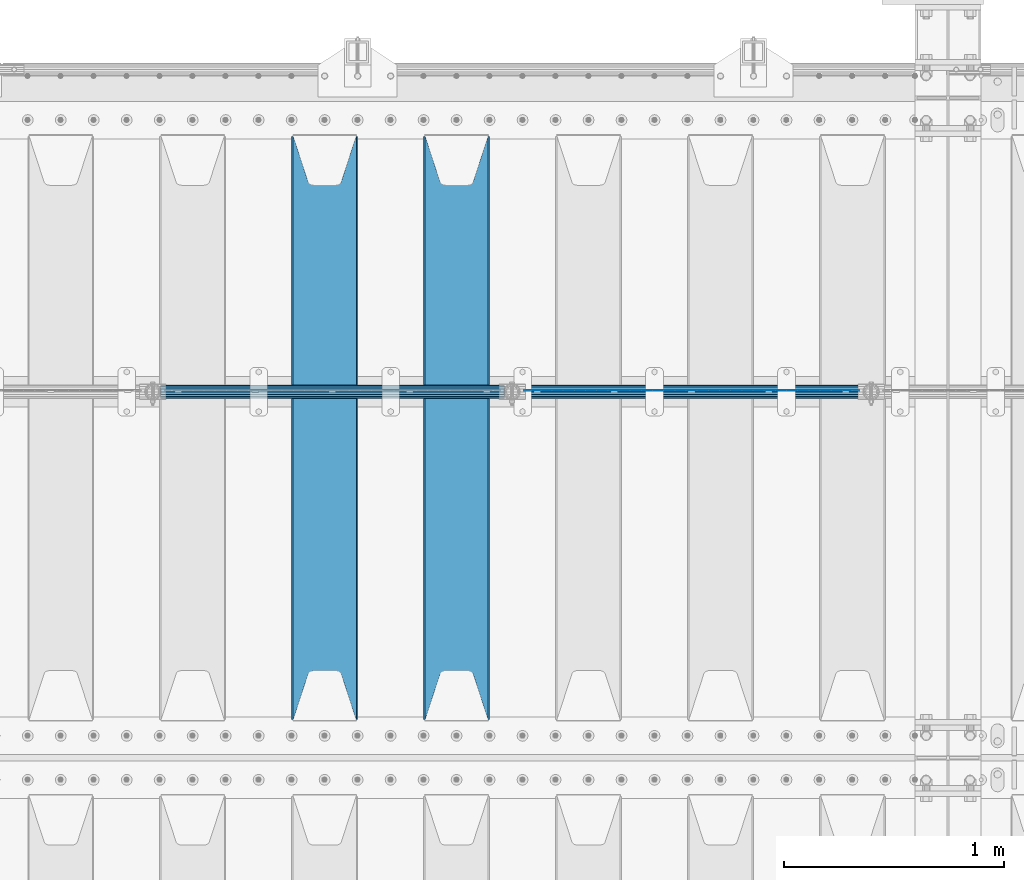
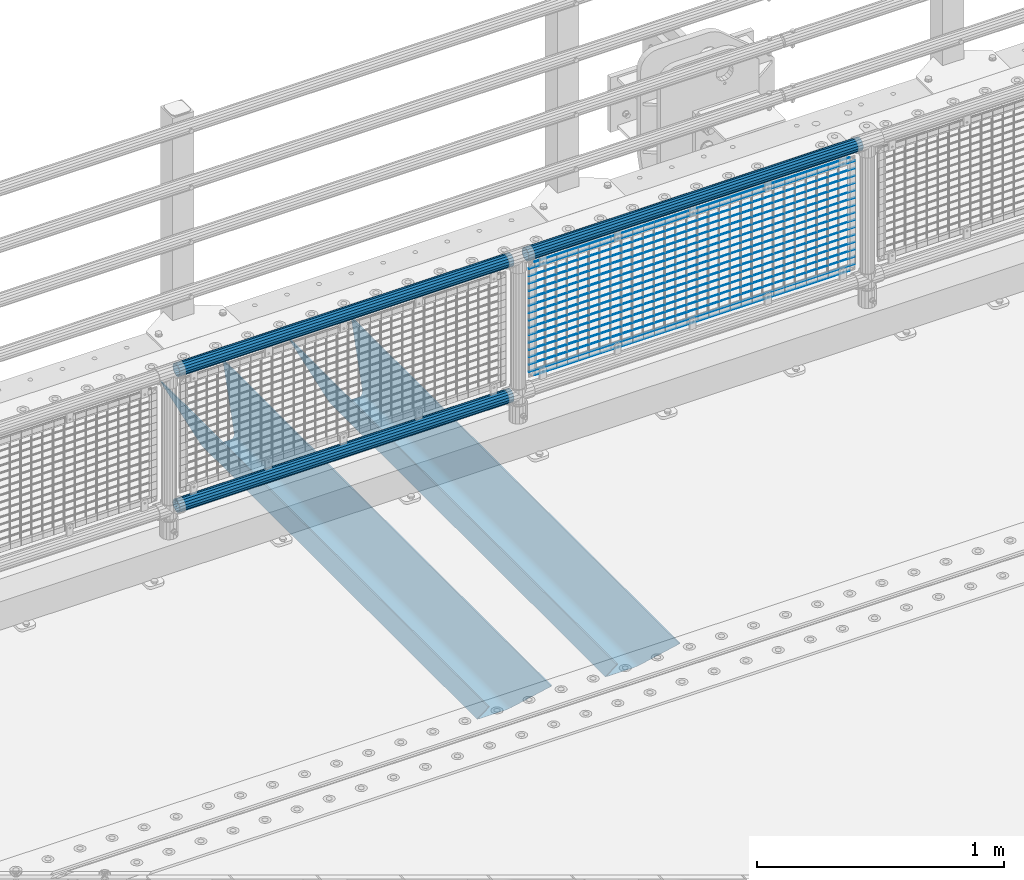
# One storey, part 125 of 242: 22 beams.
"""IFC2X3 building model written with IfcOpenShell, lengths in millimetres."""

from ifc_helpers import new_model, si_unit, frame, origin_with_axes, place, context, subcontext, project, spatial, faceted_brep, material, type_object, element, save


model = new_model("IFC2X3")

# Units and contexts
model_context = context("Model", 3, precision=1e-05, world=origin_with_axes())
body_context = subcontext(model_context, "Body", "Model", "MODEL_VIEW")
ifc_project = project(units=[si_unit("LENGTHUNIT", "METRE", prefix="MILLI"), si_unit("AREAUNIT", "SQUARE_METRE"), si_unit("VOLUMEUNIT", "CUBIC_METRE"), si_unit("MASSUNIT", "GRAM", prefix="KILO"), si_unit("TIMEUNIT", "SECOND"), si_unit("PLANEANGLEUNIT", "RADIAN"), si_unit("SOLIDANGLEUNIT", "STERADIAN"), si_unit("THERMODYNAMICTEMPERATUREUNIT", "DEGREE_CELSIUS"), si_unit("LUMINOUSINTENSITYUNIT", "LUMEN")], contexts=[model_context])

# Site, building, storey
site_placement = place(None, origin_with_axes())
site = spatial("IfcSite", under=ifc_project, at=site_placement, CompositionType="ELEMENT")
building_placement = place(site_placement, origin_with_axes())
building = spatial("IfcBuilding", under=site, at=building_placement, Name="Standard", CompositionType="ELEMENT")
storey_placement = place(building_placement, origin_with_axes())
storey = spatial("IfcBuildingStorey", under=building, at=storey_placement, Name="Undefined", CompositionType="ELEMENT", Elevation=0.0)

# Beams
ifc_material_1 = material(Name="Misc_Undefined")
beam_type_1 = type_object("IfcBeamType", Name="D3", PredefinedType="NOTDEFINED")
for number, where, z_axis, x_axis in (
    (1, (-30343.0, -19329.5, 851.596999999999), (0.0, 0.0, 1.0), (1.0, 0.0, 0.0)),
    (2, (-30343.0, -19329.5, 669.452), (0.0, 0.0, 1.0), (1.0, 0.0, 0.0)),
    (3, (-30343.0, -19329.5, 523.736), (0.0, 0.0, 1.0), (1.0, 0.0, 0.0)),
    (4, (-30343.0, -19329.5, 487.307), (0.0, 0.0, 1.0), (1.0, 0.0, 0.0)),
    (5, (-30343.0, -19329.5, 705.881), (0.0, 0.0, 1.0), (1.0, 0.0, 0.0)),
    (6, (-30343.0, -19329.5, 596.594), (0.0, 0.0, 1.0), (1.0, 0.0, 0.0)),
    (7, (-30343.0, -19329.5, 450.878), (0.0, 0.0, 1.0), (1.0, 0.0, 0.0)),
    (8, (-30343.0, -19329.5, 815.167999999999), (0.0, 0.0, 1.0), (1.0, 0.0, 0.0)),
    (9, (-30343.0, -19329.5, 888.025999999999), (0.0, 0.0, 1.0), (1.0, 0.0, 0.0)),
    (10, (-30343.0, -19329.5, 778.738999999999), (0.0, 0.0, 1.0), (1.0, 0.0, 0.0)),
    (11, (-30343.0, -19329.5, 742.309999999999), (0.0, 0.0, 1.0), (1.0, 0.0, 0.0)),
    (12, (-30343.0, -19329.5, 633.023), (0.0, 0.0, 1.0), (1.0, 0.0, 0.0)),
    (13, (-30343.0, -19329.5, 560.165), (0.0, 0.0, 1.0), (1.0, 0.0, 0.0)),
    (14, (-30343.0, -19329.5, 414.449), (0.0, 0.0, 1.0), (1.0, 0.0, 0.0)),
):
    element("IfcBeam", number, at=place(storey_placement, frame(where, z_axis=z_axis, x_axis=x_axis)), inside=storey, type_object=beam_type_1, material=ifc_material_1, ObjectType="D3", context=body_context, shape_type="Brep", body=[
        faceted_brep([(0.0, -1.50000000000364, 0.0), (-3.63797880709171e-12, -0.750000000003638, -1.29903810567669), (1523.0, -0.75, -1.29903810567669), (1523.0, -1.5, 0.0), (0.0, 0.749999999996362, -1.29903810567669), (1523.0, 0.75, -1.29903810567669), (-3.63797880709171e-12, 1.49999999999636, 0.0), (1523.0, 1.5, 0.0), (0.0, 0.749999999996362, 1.29903810567669), (1523.0, 0.75, 1.29903810567669), (-3.63797880709171e-12, -0.750000000003638, 1.29903810567669), (1523.0, -0.75, 1.29903810567669)], [[[0, 1, 2, 3]], [[1, 4, 5, 2]], [[4, 6, 7, 5]], [[6, 8, 9, 7]], [[8, 10, 11, 9]], [[10, 0, 3, 11]], [[5, 7, 9, 11, 3, 2]], [[10, 8, 6, 4, 1, 0]]]),
    ])
beam_1_placement = place(storey_placement, frame((-30318.0, -19329.5, 353.02), z_axis=(0.0, 0.0, 1.0), x_axis=(1.0, 0.0, 0.0)))
element("IfcBeam", 15, at=beam_1_placement, inside=storey, type_object=beam_type_1, material=ifc_material_1, ObjectType="D3", context=body_context, shape_type="Brep", body=[
    faceted_brep([(0.0, -1.50000000000364, 0.0), (-3.63797880709171e-12, -0.750000000003638, -1.29903810567669), (1473.0, -0.75, -1.29903810567669), (1473.0, -1.5, 0.0), (0.0, 0.749999999996362, -1.29903810567669), (1473.0, 0.75, -1.29903810567663), (-3.63797880709171e-12, 1.49999999999636, 0.0), (1473.0, 1.5, 0.0), (0.0, 0.749999999996362, 1.29903810567669), (1473.0, 0.75, 1.29903810567669), (-3.63797880709171e-12, -0.750000000003638, 1.29903810567669), (1473.0, -0.75, 1.29903810567669)], [[[0, 1, 2, 3]], [[1, 4, 5, 2]], [[4, 6, 7, 5]], [[6, 8, 9, 7]], [[8, 10, 11, 9]], [[10, 0, 3, 11]], [[5, 7, 9, 11, 3, 2]], [[10, 8, 6, 4, 1, 0]]]),
])
beam_2_placement = place(storey_placement, frame((-30343.0, -19329.5, 378.02), z_axis=(0.0, 0.0, 1.0), x_axis=(1.0, 0.0, 0.0)))
element("IfcBeam", 16, at=beam_2_placement, inside=storey, type_object=beam_type_1, material=ifc_material_1, ObjectType="D3", context=body_context, shape_type="Brep", body=[
    faceted_brep([(0.0, -1.50000000000364, 0.0), (-3.63797880709171e-12, -0.750000000003638, -1.29903810567669), (1523.0, -0.75, -1.29903810567669), (1523.0, -1.5, 0.0), (0.0, 0.749999999996362, -1.29903810567669), (1523.0, 0.75, -1.29903810567669), (-3.63797880709171e-12, 1.49999999999636, 0.0), (1523.0, 1.5, 0.0), (0.0, 0.749999999996362, 1.29903810567669), (1523.0, 0.75, 1.29903810567669), (-3.63797880709171e-12, -0.750000000003638, 1.29903810567669), (1523.0, -0.75, 1.29903810567669)], [[[0, 1, 2, 3]], [[1, 4, 5, 2]], [[4, 6, 7, 5]], [[6, 8, 9, 7]], [[8, 10, 11, 9]], [[10, 0, 3, 11]], [[5, 7, 9, 11, 3, 2]], [[10, 8, 6, 4, 1, 0]]]),
])
beam_3_placement = place(storey_placement, frame((-30318.0, -19329.5, 913.02), z_axis=(0.0, 0.0, 1.0), x_axis=(1.0, 0.0, 0.0)))
element("IfcBeam", 17, at=beam_3_placement, inside=storey, type_object=beam_type_1, material=ifc_material_1, ObjectType="D3", context=body_context, shape_type="Brep", body=[
    faceted_brep([(0.0, -1.50000000000364, 0.0), (-3.63797880709171e-12, -0.750000000003638, -1.29903810567669), (1473.0, -0.75, -1.29903810567669), (1473.0, -1.5, 0.0), (0.0, 0.749999999996362, -1.29903810567669), (1473.0, 0.75, -1.29903810567663), (-3.63797880709171e-12, 1.49999999999636, 0.0), (1473.0, 1.5, 0.0), (0.0, 0.749999999996362, 1.29903810567669), (1473.0, 0.75, 1.29903810567669), (-3.63797880709171e-12, -0.750000000003638, 1.29903810567669), (1473.0, -0.75, 1.29903810567669)], [[[0, 1, 2, 3]], [[1, 4, 5, 2]], [[4, 6, 7, 5]], [[6, 8, 9, 7]], [[8, 10, 11, 9]], [[10, 0, 3, 11]], [[5, 7, 9, 11, 3, 2]], [[10, 8, 6, 4, 1, 0]]]),
])
ifc_material_2 = material()
beam_type_2 = type_object("IfcBeamType", PredefinedType="NOTDEFINED")
beam_4_placement = place(storey_placement, frame((-30363.15, -19335.5, 969.849999999999), z_axis=(0.0, 0.0, 1.0), x_axis=(1.0, 0.0, 0.0)))
element("IfcBeam", 18, at=beam_4_placement, inside=storey, type_object=beam_type_2, material=ifc_material_2, context=body_context, shape_type="Brep", body=[
    faceted_brep([(0.0, -25.3499999999985, 0.0), (0.0, -23.4203461491597, 9.70102501045403), (1563.0, -23.4203461491597, 9.70102501045506), (1563.0, -25.3499999999985, 0.0), (0.0, -17.9251569030785, 17.9251569030785), (1563.0, -17.9251569030785, 17.925156903079), (0.0, -9.70102501045403, 23.4203461491597), (1563.0, -9.70102501045403, 23.4203461491611), (0.0, 0.0, 25.3499999999985), (1563.0, 0.0, 25.35), (0.0, 9.70102501045403, 23.4203461491597), (1563.0, 9.70102501045403, 23.4203461491611), (0.0, 17.9251569030785, 17.9251569030785), (1563.0, 17.9251569030785, 17.925156903079), (0.0, 23.4203461491597, 9.70102501045403), (1563.0, 23.4203461491597, 9.70102501045506), (0.0, 25.3499999999985, 0.0), (1563.0, 25.3499999999985, 0.0), (0.0, 23.4203461491597, -9.70102501045403), (1563.0, 23.4203461491597, -9.70102501045506), (0.0, 17.9251569030785, -17.9251569030785), (1563.0, 17.9251569030785, -17.925156903079), (0.0, 9.70102501045403, -23.4203461491597), (1563.0, 9.70102501045403, -23.4203461491611), (0.0, 0.0, -25.3499999999985), (1563.0, 0.0, -25.35), (0.0, -9.70102501045403, -23.4203461491597), (1563.0, -9.70102501045403, -23.4203461491611), (0.0, -17.9251569030785, -17.9251569030785), (1563.0, -17.9251569030785, -17.925156903079), (0.0, -23.4203461491597, -9.70102501045403), (1563.0, -23.4203461491597, -9.70102501045506), (0.0, -30.1500000000015, 0.0), (0.0, -27.8549679052157, -11.5379054858058), (1563.0, -27.8549679052157, -11.5379054858075), (1563.0, -30.1500000000015, 0.0), (0.0, -21.3192694527752, -21.3192694527752), (1563.0, -21.3192694527752, -21.3192694527744), (0.0, -11.5379054858058, -27.8549679052157), (1563.0, -11.5379054858058, -27.8549679052153), (0.0, 0.0, -30.1500000000015), (1563.0, 0.0, -30.15), (0.0, 11.5379054858058, -27.8549679052157), (1563.0, 11.5379054858058, -27.8549679052153), (0.0, 21.3192694527752, -21.3192694527752), (1563.0, 21.3192694527752, -21.3192694527744), (0.0, 27.8549679052157, -11.5379054858058), (1563.0, 27.8549679052157, -11.5379054858074), (0.0, 30.1500000000015, 0.0), (1563.0, 30.1500000000015, 0.0), (0.0, 27.8549679052157, 11.5379054858058), (1563.0, 27.8549679052157, 11.5379054858074), (0.0, 21.3192694527752, 21.3192694527752), (1563.0, 21.3192694527752, 21.3192694527744), (0.0, 11.5379054858058, 27.8549679052157), (1563.0, 11.5379054858058, 27.8549679052153), (0.0, 0.0, 30.1500000000015), (1563.0, 0.0, 30.15), (0.0, -11.5379054858058, 27.8549679052157), (1563.0, -11.5379054858058, 27.8549679052153), (0.0, -21.3192694527752, 21.3192694527752), (1563.0, -21.3192694527752, 21.3192694527744), (0.0, -27.8549679052157, 11.5379054858058), (1563.0, -27.8549679052157, 11.5379054858074)], [[[0, 1, 2, 3]], [[1, 4, 5, 2]], [[4, 6, 7, 5]], [[6, 8, 9, 7]], [[8, 10, 11, 9]], [[10, 12, 13, 11]], [[12, 14, 15, 13]], [[14, 16, 17, 15]], [[16, 18, 19, 17]], [[18, 20, 21, 19]], [[20, 22, 23, 21]], [[22, 24, 25, 23]], [[24, 26, 27, 25]], [[26, 28, 29, 27]], [[28, 30, 31, 29]], [[30, 0, 3, 31]], [[32, 33, 34, 35]], [[33, 36, 37, 34]], [[36, 38, 39, 37]], [[38, 40, 41, 39]], [[40, 42, 43, 41]], [[42, 44, 45, 43]], [[44, 46, 47, 45]], [[46, 48, 49, 47]], [[48, 50, 51, 49]], [[50, 52, 53, 51]], [[52, 54, 55, 53]], [[54, 56, 57, 55]], [[56, 58, 59, 57]], [[58, 60, 61, 59]], [[60, 62, 63, 61]], [[62, 32, 35, 63]], [[37, 39, 41, 43, 45, 47, 49, 51, 53, 55, 57, 59, 61, 63, 35, 34], [5, 7, 9, 11, 13, 15, 17, 19, 21, 23, 25, 27, 29, 31, 3, 2]], [[62, 60, 58, 56, 54, 52, 50, 48, 46, 44, 42, 40, 38, 36, 33, 32], [30, 28, 26, 24, 22, 20, 18, 16, 14, 12, 10, 8, 6, 4, 1, 0]]]),
])
beam_5_placement = place(storey_placement, frame((-31996.15, -19335.5, 969.849999999999), z_axis=(0.0, 0.0, 1.0), x_axis=(1.0, 0.0, 0.0)))
element("IfcBeam", 19, at=beam_5_placement, inside=storey, type_object=beam_type_2, material=ifc_material_2, context=body_context, shape_type="Brep", body=[
    faceted_brep([(0.0, -25.3499999999985, 0.0), (0.0, -23.4203461491597, 9.70102501045403), (1563.0, -23.4203461491597, 9.70102501045506), (1563.0, -25.3499999999985, 0.0), (0.0, -17.9251569030785, 17.9251569030785), (1563.0, -17.9251569030785, 17.925156903079), (0.0, -9.70102501045403, 23.4203461491597), (1563.0, -9.70102501045403, 23.4203461491611), (0.0, 0.0, 25.3499999999985), (1563.0, 0.0, 25.35), (0.0, 9.70102501045403, 23.4203461491597), (1563.0, 9.70102501045403, 23.4203461491611), (0.0, 17.9251569030785, 17.9251569030785), (1563.0, 17.9251569030785, 17.925156903079), (0.0, 23.4203461491597, 9.70102501045403), (1563.0, 23.4203461491597, 9.70102501045506), (0.0, 25.3499999999985, 0.0), (1563.0, 25.3499999999985, 0.0), (0.0, 23.4203461491597, -9.70102501045403), (1563.0, 23.4203461491597, -9.70102501045506), (0.0, 17.9251569030785, -17.9251569030785), (1563.0, 17.9251569030785, -17.925156903079), (0.0, 9.70102501045403, -23.4203461491597), (1563.0, 9.70102501045403, -23.4203461491611), (0.0, 0.0, -25.3499999999985), (1563.0, 0.0, -25.35), (0.0, -9.70102501045403, -23.4203461491597), (1563.0, -9.70102501045403, -23.4203461491611), (0.0, -17.9251569030785, -17.9251569030785), (1563.0, -17.9251569030785, -17.925156903079), (0.0, -23.4203461491597, -9.70102501045403), (1563.0, -23.4203461491597, -9.70102501045506), (0.0, -30.1500000000015, 0.0), (0.0, -27.8549679052157, -11.5379054858058), (1563.0, -27.8549679052157, -11.5379054858075), (1563.0, -30.1500000000015, 0.0), (0.0, -21.3192694527752, -21.3192694527752), (1563.0, -21.3192694527752, -21.3192694527744), (0.0, -11.5379054858058, -27.8549679052157), (1563.0, -11.5379054858058, -27.8549679052153), (0.0, 0.0, -30.1500000000015), (1563.0, 0.0, -30.15), (0.0, 11.5379054858058, -27.8549679052157), (1563.0, 11.5379054858058, -27.8549679052153), (0.0, 21.3192694527752, -21.3192694527752), (1563.0, 21.3192694527752, -21.3192694527744), (0.0, 27.8549679052157, -11.5379054858058), (1563.0, 27.8549679052157, -11.5379054858074), (0.0, 30.1500000000015, 0.0), (1563.0, 30.1500000000015, 0.0), (0.0, 27.8549679052157, 11.5379054858058), (1563.0, 27.8549679052157, 11.5379054858074), (0.0, 21.3192694527752, 21.3192694527752), (1563.0, 21.3192694527752, 21.3192694527744), (0.0, 11.5379054858058, 27.8549679052157), (1563.0, 11.5379054858058, 27.8549679052153), (0.0, 0.0, 30.1500000000015), (1563.0, 0.0, 30.15), (0.0, -11.5379054858058, 27.8549679052157), (1563.0, -11.5379054858058, 27.8549679052153), (0.0, -21.3192694527752, 21.3192694527752), (1563.0, -21.3192694527752, 21.3192694527744), (0.0, -27.8549679052157, 11.5379054858058), (1563.0, -27.8549679052157, 11.5379054858074)], [[[0, 1, 2, 3]], [[1, 4, 5, 2]], [[4, 6, 7, 5]], [[6, 8, 9, 7]], [[8, 10, 11, 9]], [[10, 12, 13, 11]], [[12, 14, 15, 13]], [[14, 16, 17, 15]], [[16, 18, 19, 17]], [[18, 20, 21, 19]], [[20, 22, 23, 21]], [[22, 24, 25, 23]], [[24, 26, 27, 25]], [[26, 28, 29, 27]], [[28, 30, 31, 29]], [[30, 0, 3, 31]], [[32, 33, 34, 35]], [[33, 36, 37, 34]], [[36, 38, 39, 37]], [[38, 40, 41, 39]], [[40, 42, 43, 41]], [[42, 44, 45, 43]], [[44, 46, 47, 45]], [[46, 48, 49, 47]], [[48, 50, 51, 49]], [[50, 52, 53, 51]], [[52, 54, 55, 53]], [[54, 56, 57, 55]], [[56, 58, 59, 57]], [[58, 60, 61, 59]], [[60, 62, 63, 61]], [[62, 32, 35, 63]], [[37, 39, 41, 43, 45, 47, 49, 51, 53, 55, 57, 59, 61, 63, 35, 34], [5, 7, 9, 11, 13, 15, 17, 19, 21, 23, 25, 27, 29, 31, 3, 2]], [[62, 60, 58, 56, 54, 52, 50, 48, 46, 44, 42, 40, 38, 36, 33, 32], [30, 28, 26, 24, 22, 20, 18, 16, 14, 12, 10, 8, 6, 4, 1, 0]]]),
])
beam_6_placement = place(storey_placement, frame((-31996.15, -19335.5, 298.170000000001), z_axis=(0.0, 0.0, 1.0), x_axis=(1.0, 0.0, 0.0)))
element("IfcBeam", 20, at=beam_6_placement, inside=storey, type_object=beam_type_2, material=ifc_material_2, context=body_context, shape_type="Brep", body=[
    faceted_brep([(0.0, -25.3499999999985, 0.0), (0.0, -23.4203461491597, 9.70102501045403), (1563.0, -23.4203461491597, 9.70102501045506), (1563.0, -25.3499999999985, 0.0), (0.0, -17.9251569030785, 17.9251569030785), (1563.0, -17.9251569030785, 17.925156903079), (0.0, -9.70102501045403, 23.4203461491597), (1563.0, -9.70102501045403, 23.4203461491611), (0.0, 0.0, 25.3499999999985), (1563.0, 0.0, 25.35), (0.0, 9.70102501045403, 23.4203461491597), (1563.0, 9.70102501045403, 23.4203461491611), (0.0, 17.9251569030785, 17.9251569030785), (1563.0, 17.9251569030785, 17.925156903079), (0.0, 23.4203461491597, 9.70102501045403), (1563.0, 23.4203461491597, 9.70102501045506), (0.0, 25.3499999999985, 0.0), (1563.0, 25.3499999999985, 0.0), (0.0, 23.4203461491597, -9.70102501045403), (1563.0, 23.4203461491597, -9.70102501045506), (0.0, 17.9251569030785, -17.9251569030785), (1563.0, 17.9251569030785, -17.925156903079), (0.0, 9.70102501045403, -23.4203461491597), (1563.0, 9.70102501045403, -23.4203461491611), (0.0, 0.0, -25.3499999999985), (1563.0, 0.0, -25.35), (0.0, -9.70102501045403, -23.4203461491597), (1563.0, -9.70102501045403, -23.4203461491611), (0.0, -17.9251569030785, -17.9251569030785), (1563.0, -17.9251569030785, -17.925156903079), (0.0, -23.4203461491597, -9.70102501045403), (1563.0, -23.4203461491597, -9.70102501045506), (0.0, -30.1500000000015, 0.0), (0.0, -27.8549679052157, -11.5379054858058), (1563.0, -27.8549679052157, -11.5379054858075), (1563.0, -30.1500000000015, 0.0), (0.0, -21.3192694527752, -21.3192694527752), (1563.0, -21.3192694527752, -21.3192694527744), (0.0, -11.5379054858058, -27.8549679052157), (1563.0, -11.5379054858058, -27.8549679052153), (0.0, 0.0, -30.1500000000015), (1563.0, 0.0, -30.15), (0.0, 11.5379054858058, -27.8549679052157), (1563.0, 11.5379054858058, -27.8549679052153), (0.0, 21.3192694527752, -21.3192694527752), (1563.0, 21.3192694527752, -21.3192694527744), (0.0, 27.8549679052157, -11.5379054858058), (1563.0, 27.8549679052157, -11.5379054858074), (0.0, 30.1500000000015, 0.0), (1563.0, 30.1500000000015, 0.0), (0.0, 27.8549679052157, 11.5379054858058), (1563.0, 27.8549679052157, 11.5379054858074), (0.0, 21.3192694527752, 21.3192694527752), (1563.0, 21.3192694527752, 21.3192694527744), (0.0, 11.5379054858058, 27.8549679052157), (1563.0, 11.5379054858058, 27.8549679052153), (0.0, 0.0, 30.1500000000015), (1563.0, 0.0, 30.15), (0.0, -11.5379054858058, 27.8549679052157), (1563.0, -11.5379054858058, 27.8549679052153), (0.0, -21.3192694527752, 21.3192694527752), (1563.0, -21.3192694527752, 21.3192694527744), (0.0, -27.8549679052157, 11.5379054858058), (1563.0, -27.8549679052157, 11.5379054858074)], [[[0, 1, 2, 3]], [[1, 4, 5, 2]], [[4, 6, 7, 5]], [[6, 8, 9, 7]], [[8, 10, 11, 9]], [[10, 12, 13, 11]], [[12, 14, 15, 13]], [[14, 16, 17, 15]], [[16, 18, 19, 17]], [[18, 20, 21, 19]], [[20, 22, 23, 21]], [[22, 24, 25, 23]], [[24, 26, 27, 25]], [[26, 28, 29, 27]], [[28, 30, 31, 29]], [[30, 0, 3, 31]], [[32, 33, 34, 35]], [[33, 36, 37, 34]], [[36, 38, 39, 37]], [[38, 40, 41, 39]], [[40, 42, 43, 41]], [[42, 44, 45, 43]], [[44, 46, 47, 45]], [[46, 48, 49, 47]], [[48, 50, 51, 49]], [[50, 52, 53, 51]], [[52, 54, 55, 53]], [[54, 56, 57, 55]], [[56, 58, 59, 57]], [[58, 60, 61, 59]], [[60, 62, 63, 61]], [[62, 32, 35, 63]], [[37, 39, 41, 43, 45, 47, 49, 51, 53, 55, 57, 59, 61, 63, 35, 34], [5, 7, 9, 11, 13, 15, 17, 19, 21, 23, 25, 27, 29, 31, 3, 2]], [[62, 60, 58, 56, 54, 52, 50, 48, 46, 44, 42, 40, 38, 36, 33, 32], [30, 28, 26, 24, 22, 20, 18, 16, 14, 12, 10, 8, 6, 4, 1, 0]]]),
])
ifc_material_3 = material(Name="STEEL/S355N")
beam_type_3 = type_object("IfcBeamType", PredefinedType="NOTDEFINED")
beam_7_placement = place(storey_placement, frame((-30650.0, -20825.0, -115.0), z_axis=(0.0, 0.0, 1.0), x_axis=(0.0, 1.0, 0.0)))
element("IfcBeam", 21, at=beam_7_placement, inside=storey, type_object=beam_type_3, material=ifc_material_3, context=body_context, shape_type="Brep", body=[
    faceted_brep([(0.0, 150.0, 115.0), (0.0, 143.689999999999, 115.0), (2650.00000000297, 143.689999999999, 115.0), (2650.00000000297, 150.0, 115.0), (2650.00000000297, 142.059565218402, 110.000000003099), (2650.00000000297, 148.369565218403, 110.000000003099), (2441.90079219209, -80.1103600731112, -98.0992078077845), (2437.7588105432, -77.5672621345584, -102.241189456673), (2434.06523489747, -74.4080125315522, -105.934765102404), (2430.91086095089, -70.710272125576, -109.089139048974), (2428.37322971128, -66.5649389910068, -111.626770288588), (2426.51472138055, -62.0739139532889, -113.485278619323), (2425.38102192092, -57.3475956567672, -114.618978078955), (2424.99999999987, -52.5021667386536, -115.0), (2424.99999999987, 52.5021667386536, -115.0), (2425.38102192092, 57.3475956567672, -114.618978078955), (2426.51472138055, 62.0739139532889, -113.485278619323), (2428.37322971128, 66.5649389910068, -111.626770288588), (2430.91086095089, 70.710272125576, -109.089139048974), (2434.06523489747, 74.4080125315522, -105.934765102404), (2437.7588105432, 77.5672621345584, -102.241189456673), (2441.90079219209, 80.1103600731112, -98.0992078077846), (2446.38936140511, 81.9747917625791, -93.6106385947584), (2448.2494850041, 76.2713538057251, -91.7505149957729), (2444.62967112262, 74.76777986261, -95.3703288772456), (2441.28936334126, 72.7168944282894, -98.710636658607), (2438.31067330438, 70.1691124903846, -101.689326695487), (2435.76682334747, 67.1870637758839, -104.233176652398), (2433.72034654133, 63.8440531834895, -106.279653458539), (2432.22154950042, 60.222258798236, -107.778450499454), (2431.30727574265, 56.4107117849089, -108.692724257221), (2430.99999999987, 52.5031078186876, -109.0), (2430.99999999987, -52.5031078186876, -109.0), (2431.30727574265, -56.4107117849089, -108.692724257221), (2432.22154950042, -60.222258798236, -107.778450499454), (2433.72034654133, -63.8440531834895, -106.279653458539), (2435.76682334747, -67.1870637758839, -104.233176652398), (2438.31067330438, -70.1691124903846, -101.689326695487), (2441.28936334126, -72.7168944282894, -98.7106366586071), (2444.62967112262, -74.76777986261, -95.3703288772457), (2448.2494850041, -76.2713538057251, -91.7505149957729), (2650.00000000297, -142.059565218402, 110.000000003099), (2650.00000000297, -148.369565218403, 110.000000003099), (2446.38936140511, -81.9747917625791, -93.6106385947584), (2650.00000000297, -143.689999999999, 115.0), (2650.00000000297, -150.0, 115.0), (0.0, -143.689999999999, 115.0), (0.0, -150.0, 115.0), (0.0, -148.369565218261, 110.000000002669), (203.610638597427, -81.9747917625791, -93.6106385947584), (208.099207810454, -80.1103600731112, -98.0992078077845), (212.241189459342, -77.5672621345584, -102.241189456673), (215.934765105074, -74.4080125315522, -105.934765102404), (219.089139051644, -70.710272125576, -109.089139048974), (221.626770291256, -66.5649389910068, -111.626770288588), (223.485278621993, -62.0739139532889, -113.485278619323), (224.618978081624, -57.3475956567672, -114.618978078955), (225.00000000267, -52.5021667386536, -115.0), (225.00000000267, 52.5021667386536, -115.0), (224.618978081624, 57.3475956567672, -114.618978078955), (223.485278621993, 62.0739139532889, -113.485278619323), (221.626770291256, 66.5649389910068, -111.626770288588), (219.089139051644, 70.710272125576, -109.089139048974), (215.934765105074, 74.4080125315522, -105.934765102404), (212.241189459342, 77.5672621345584, -102.241189456673), (208.099207810454, 80.1103600731112, -98.0992078077846), (203.610638597427, 81.9747917625791, -93.6106385947584), (0.0, 148.369565218261, 110.000000002669), (0.0, 142.05956521826, 110.000000002669), (201.750514998443, 76.2713538057251, -91.7505149957729), (205.370328879915, 74.76777986261, -95.3703288772456), (208.710636661275, 72.7168944282894, -98.710636658607), (211.689326698157, 70.1691124903846, -101.689326695487), (214.233176655067, 67.1870637758839, -104.233176652398), (216.279653461206, 63.8440531834895, -106.279653458539), (217.778450502123, 60.222258798236, -107.778450499454), (218.69272425989, 56.4107117849089, -108.692724257221), (219.00000000267, 52.5031078186876, -109.0), (219.00000000267, -52.5031078186876, -109.0), (218.69272425989, -56.4107117849089, -108.692724257221), (217.778450502123, -60.222258798236, -107.778450499454), (216.279653461206, -63.8440531834895, -106.279653458539), (214.233176655067, -67.1870637758839, -104.233176652398), (211.689326698157, -70.1691124903846, -101.689326695487), (208.710636661275, -72.7168944282894, -98.7106366586071), (205.370328879915, -74.76777986261, -95.3703288772457), (201.750514998443, -76.2713538057251, -91.7505149957729), (0.0, -142.05956521826, 110.000000002669)], [[[0, 1, 2, 3]], [[3, 2, 4, 5]], [[6, 7, 8, 9, 10, 11, 12, 13, 14, 15, 16, 17, 18, 19, 20, 21, 22, 5, 4, 23, 24, 25, 26, 27, 28, 29, 30, 31, 32, 33, 34, 35, 36, 37, 38, 39, 40, 41, 42, 43]], [[44, 45, 42, 41]], [[46, 47, 45, 44]], [[43, 42, 45, 47, 48, 49]], [[6, 43, 49, 50]], [[7, 6, 50, 51]], [[8, 7, 51, 52]], [[9, 8, 52, 53]], [[10, 9, 53, 54]], [[11, 10, 54, 55]], [[12, 11, 55, 56]], [[13, 12, 56, 57]], [[14, 13, 57, 58]], [[15, 14, 58, 59]], [[16, 15, 59, 60]], [[17, 16, 60, 61]], [[18, 17, 61, 62]], [[19, 18, 62, 63]], [[20, 19, 63, 64]], [[21, 20, 64, 65]], [[22, 21, 65, 66]], [[0, 3, 5, 22, 66, 67]], [[1, 0, 67, 68]], [[23, 4, 2, 1, 68, 69]], [[24, 23, 69, 70]], [[25, 24, 70, 71]], [[26, 25, 71, 72]], [[27, 26, 72, 73]], [[28, 27, 73, 74]], [[29, 28, 74, 75]], [[30, 29, 75, 76]], [[31, 30, 76, 77]], [[32, 31, 77, 78]], [[33, 32, 78, 79]], [[34, 33, 79, 80]], [[35, 34, 80, 81]], [[36, 35, 81, 82]], [[37, 36, 82, 83]], [[38, 37, 83, 84]], [[39, 38, 84, 85]], [[40, 39, 85, 86]], [[46, 44, 41, 40, 86, 87]], [[47, 46, 87, 48]], [[86, 85, 84, 83, 82, 81, 80, 79, 78, 77, 76, 75, 74, 73, 72, 71, 70, 69, 68, 67, 66, 65, 64, 63, 62, 61, 60, 59, 58, 57, 56, 55, 54, 53, 52, 51, 50, 49, 48, 87]]]),
])
beam_8_placement = place(storey_placement, frame((-31250.0, -20825.0, -115.0), z_axis=(0.0, 0.0, 1.0), x_axis=(0.0, 1.0, 0.0)))
element("IfcBeam", 22, at=beam_8_placement, inside=storey, type_object=beam_type_3, material=ifc_material_3, context=body_context, shape_type="Brep", body=[
    faceted_brep([(0.0, 150.0, 115.0), (0.0, 143.689999999999, 115.0), (2650.00000000297, 143.689999999999, 115.0), (2650.00000000297, 150.0, 115.0), (2650.00000000297, 142.059565218402, 110.000000003099), (2650.00000000297, 148.369565218403, 110.000000003099), (2441.90079219209, -80.1103600731112, -98.0992078077845), (2437.7588105432, -77.5672621345584, -102.241189456673), (2434.06523489747, -74.4080125315522, -105.934765102404), (2430.91086095089, -70.710272125576, -109.089139048974), (2428.37322971128, -66.5649389910068, -111.626770288588), (2426.51472138055, -62.0739139532889, -113.485278619323), (2425.38102192092, -57.3475956567672, -114.618978078955), (2424.99999999987, -52.5021667386536, -115.0), (2424.99999999987, 52.5021667386536, -115.0), (2425.38102192092, 57.3475956567672, -114.618978078955), (2426.51472138055, 62.0739139532889, -113.485278619323), (2428.37322971128, 66.5649389910068, -111.626770288588), (2430.91086095089, 70.710272125576, -109.089139048974), (2434.06523489747, 74.4080125315522, -105.934765102404), (2437.7588105432, 77.5672621345584, -102.241189456673), (2441.90079219209, 80.1103600731112, -98.0992078077846), (2446.38936140511, 81.9747917625791, -93.6106385947584), (2448.2494850041, 76.2713538057251, -91.7505149957729), (2444.62967112262, 74.76777986261, -95.3703288772456), (2441.28936334126, 72.7168944282894, -98.710636658607), (2438.31067330438, 70.1691124903846, -101.689326695487), (2435.76682334747, 67.1870637758839, -104.233176652398), (2433.72034654133, 63.8440531834895, -106.279653458539), (2432.22154950042, 60.222258798236, -107.778450499454), (2431.30727574265, 56.4107117849089, -108.692724257221), (2430.99999999987, 52.5031078186876, -109.0), (2430.99999999987, -52.5031078186876, -109.0), (2431.30727574265, -56.4107117849089, -108.692724257221), (2432.22154950042, -60.222258798236, -107.778450499454), (2433.72034654133, -63.8440531834895, -106.279653458539), (2435.76682334747, -67.1870637758839, -104.233176652398), (2438.31067330438, -70.1691124903846, -101.689326695487), (2441.28936334126, -72.7168944282894, -98.7106366586071), (2444.62967112262, -74.76777986261, -95.3703288772457), (2448.2494850041, -76.2713538057251, -91.7505149957729), (2650.00000000297, -142.059565218402, 110.000000003099), (2650.00000000297, -148.369565218403, 110.000000003099), (2446.38936140511, -81.9747917625791, -93.6106385947584), (2650.00000000297, -143.689999999999, 115.0), (2650.00000000297, -150.0, 115.0), (0.0, -143.689999999999, 115.0), (0.0, -150.0, 115.0), (0.0, -148.369565218261, 110.000000002669), (203.610638597427, -81.9747917625791, -93.6106385947584), (208.099207810454, -80.1103600731112, -98.0992078077845), (212.241189459342, -77.5672621345584, -102.241189456673), (215.934765105074, -74.4080125315522, -105.934765102404), (219.089139051644, -70.710272125576, -109.089139048974), (221.626770291256, -66.5649389910068, -111.626770288588), (223.485278621993, -62.0739139532889, -113.485278619323), (224.618978081624, -57.3475956567672, -114.618978078955), (225.00000000267, -52.5021667386536, -115.0), (225.00000000267, 52.5021667386536, -115.0), (224.618978081624, 57.3475956567672, -114.618978078955), (223.485278621993, 62.0739139532889, -113.485278619323), (221.626770291256, 66.5649389910068, -111.626770288588), (219.089139051644, 70.710272125576, -109.089139048974), (215.934765105074, 74.4080125315522, -105.934765102404), (212.241189459342, 77.5672621345584, -102.241189456673), (208.099207810454, 80.1103600731112, -98.0992078077846), (203.610638597427, 81.9747917625791, -93.6106385947584), (0.0, 148.369565218261, 110.000000002669), (0.0, 142.05956521826, 110.000000002669), (201.750514998443, 76.2713538057251, -91.7505149957729), (205.370328879915, 74.76777986261, -95.3703288772456), (208.710636661275, 72.7168944282894, -98.710636658607), (211.689326698157, 70.1691124903846, -101.689326695487), (214.233176655067, 67.1870637758839, -104.233176652398), (216.279653461206, 63.8440531834895, -106.279653458539), (217.778450502123, 60.222258798236, -107.778450499454), (218.69272425989, 56.4107117849089, -108.692724257221), (219.00000000267, 52.5031078186876, -109.0), (219.00000000267, -52.5031078186876, -109.0), (218.69272425989, -56.4107117849089, -108.692724257221), (217.778450502123, -60.222258798236, -107.778450499454), (216.279653461206, -63.8440531834895, -106.279653458539), (214.233176655067, -67.1870637758839, -104.233176652398), (211.689326698157, -70.1691124903846, -101.689326695487), (208.710636661275, -72.7168944282894, -98.7106366586071), (205.370328879915, -74.76777986261, -95.3703288772457), (201.750514998443, -76.2713538057251, -91.7505149957729), (0.0, -142.05956521826, 110.000000002669)], [[[0, 1, 2, 3]], [[3, 2, 4, 5]], [[6, 7, 8, 9, 10, 11, 12, 13, 14, 15, 16, 17, 18, 19, 20, 21, 22, 5, 4, 23, 24, 25, 26, 27, 28, 29, 30, 31, 32, 33, 34, 35, 36, 37, 38, 39, 40, 41, 42, 43]], [[44, 45, 42, 41]], [[46, 47, 45, 44]], [[43, 42, 45, 47, 48, 49]], [[6, 43, 49, 50]], [[7, 6, 50, 51]], [[8, 7, 51, 52]], [[9, 8, 52, 53]], [[10, 9, 53, 54]], [[11, 10, 54, 55]], [[12, 11, 55, 56]], [[13, 12, 56, 57]], [[14, 13, 57, 58]], [[15, 14, 58, 59]], [[16, 15, 59, 60]], [[17, 16, 60, 61]], [[18, 17, 61, 62]], [[19, 18, 62, 63]], [[20, 19, 63, 64]], [[21, 20, 64, 65]], [[22, 21, 65, 66]], [[0, 3, 5, 22, 66, 67]], [[1, 0, 67, 68]], [[23, 4, 2, 1, 68, 69]], [[24, 23, 69, 70]], [[25, 24, 70, 71]], [[26, 25, 71, 72]], [[27, 26, 72, 73]], [[28, 27, 73, 74]], [[29, 28, 74, 75]], [[30, 29, 75, 76]], [[31, 30, 76, 77]], [[32, 31, 77, 78]], [[33, 32, 78, 79]], [[34, 33, 79, 80]], [[35, 34, 80, 81]], [[36, 35, 81, 82]], [[37, 36, 82, 83]], [[38, 37, 83, 84]], [[39, 38, 84, 85]], [[40, 39, 85, 86]], [[46, 44, 41, 40, 86, 87]], [[47, 46, 87, 48]], [[86, 85, 84, 83, 82, 81, 80, 79, 78, 77, 76, 75, 74, 73, 72, 71, 70, 69, 68, 67, 66, 65, 64, 63, 62, 61, 60, 59, 58, 57, 56, 55, 54, 53, 52, 51, 50, 49, 48, 87]]]),
])

save(model, "model.ifc")
